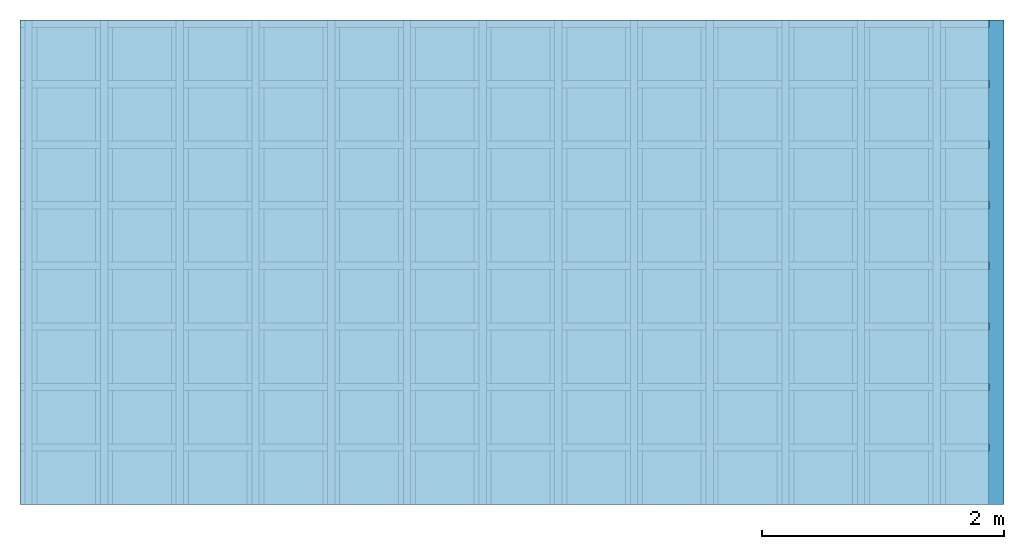
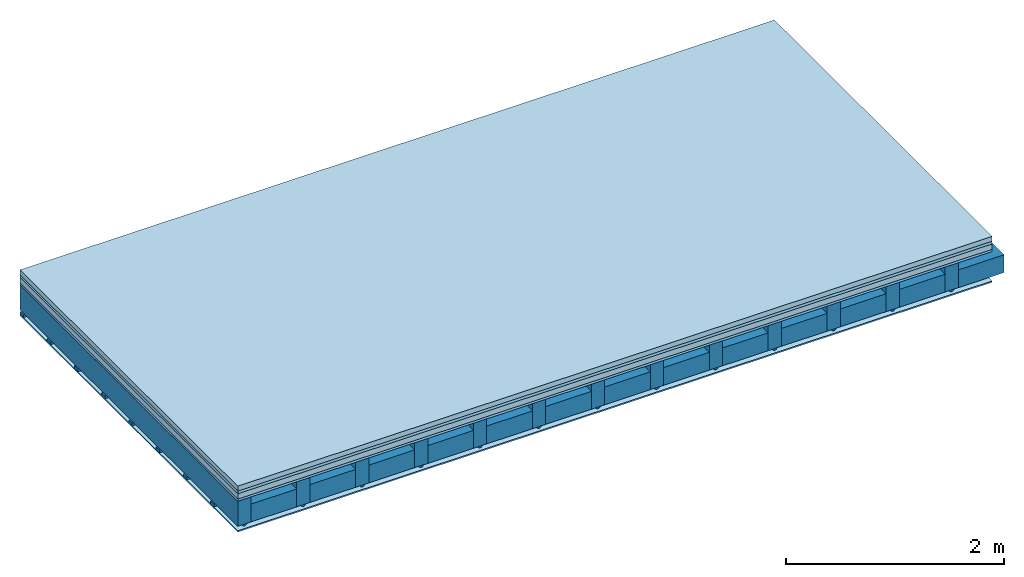
# One storey: 5 plates, 4 members, 1 element without a shape of its own.
"""IFC4 building model written with IfcOpenShell, lengths in metres."""

from ifc_helpers import new_model, si_unit, derived_unit, direction, frame, frame_2d, origin, origin_with_axes, place, context, project, spatial, polyline, rectangle, outline, extrude, material, layer, layer_set, type_object, element, aggregate, save


model = new_model("IFC4")

# Units and contexts
plan_context = context("Plan", 3, precision=1e-05, world=origin(), true_north=direction((0.0, 1.0)))
model_context = context("Model", 3, precision=1e-05, world=origin(), true_north=direction((0.0, 1.0)))
ifc_project = project(units=[si_unit("LENGTHUNIT", "METRE"), derived_unit("SOUNDPRESSUREUNIT", [(si_unit("PRESSUREUNIT", "PASCAL", prefix="MICRO"), 0)]), si_unit("ENERGYUNIT", "JOULE", prefix="MEGA"), si_unit("MASSUNIT", "GRAM", prefix="KILO"), derived_unit("THERMALTRANSMITTANCEUNIT", [(si_unit("POWERUNIT", "WATT"), 1), (si_unit("AREAUNIT", "SQUARE_METRE"), -1), (si_unit("THERMODYNAMICTEMPERATUREUNIT", "KELVIN"), -1)]), derived_unit("AREADENSITYUNIT", [(si_unit("MASSUNIT", "GRAM", prefix="KILO"), 1), (si_unit("AREAUNIT", "SQUARE_METRE"), -1)]), derived_unit("USERDEFINED", [(si_unit("ENERGYUNIT", "JOULE", prefix="MEGA"), 1), (si_unit("AREAUNIT", "SQUARE_METRE"), -1)])], contexts=[plan_context, model_context])

# Site, building, storey
site = spatial("IfcSite", under=ifc_project)
building_placement = place(None, origin())
building = spatial("IfcBuilding", under=site, at=building_placement)
storey_placement = place(building_placement, origin())
storey = spatial("IfcBuildingStorey", under=building, at=storey_placement)

# Slab, members, plates
ifc_material_1 = material(Category="04.005")
ifc_layer_1 = layer(ifc_material_1, 0.055, Name="On-material")
ifc_material_2 = material()
ifc_layer_2 = layer(ifc_material_2, 0.03, Name="Impact sound insulation")
ifc_material_3 = material(Name="Cement panels, glued on sub-floor", Category="02.007")
ifc_layer_3 = layer(ifc_material_3, 0.06, Name="on Supporting structure")
ifc_material_4 = material(Category="07.001")
ifc_layer_4 = layer(ifc_material_4, 0.025, Name="Sub-floor")
ifc_material_5 = material(Name="of the art")
ifc_layer_5 = layer(ifc_material_5, 0.0, Name="Bond")
ifc_layer_6 = layer(None, 0.28, Name="Supporting structure")
ifc_material_6 = material(Name="no composite action")
ifc_layer_7 = layer(ifc_material_6, 0.0, Name="Bond")
ifc_layer_8 = layer(None, 0.02, Name="Coupling")
ifc_layer_9 = layer(None, 0.03, Name="Battens / profiles")
ifc_material_7 = material(Category="03.007")
ifc_layer_10 = layer(ifc_material_7, 0.015, Name="Ceiling covering 1st layer")
ifc_material_8 = material(Name="Glued joints")
ifc_layer_11 = layer(ifc_material_8, 0.0, Name="Surface / treatment")
ifc_layer_set = layer_set([ifc_layer_1, ifc_layer_2, ifc_layer_3, ifc_layer_4, ifc_layer_5, ifc_layer_6, ifc_layer_7, ifc_layer_8, ifc_layer_9, ifc_layer_10, ifc_layer_11])
slab_type = type_object("IfcSlabType", Name="A0255", PredefinedType="NOTDEFINED", material=ifc_layer_set)
slab_placement = place(None, frame((0.0, 0.0, 0.0), z_axis=(0.0, 0.0, -1.0), x_axis=(1.0, 0.0, 0.0)))
slab = element("IfcSlab", 1, at=slab_placement, inside=storey, type_object=slab_type, material=ifc_layer_set, Name="Slab #1")
ifc_material_9 = material()
member_1_placement = place(slab_placement, origin())
member_1 = element("IfcMember", 2, at=member_1_placement, material=ifc_material_9, Name="Supporting structure", context=plan_context, shape_type="SweptSolid", body=[
    extrude(rectangle(XDim=0.14, YDim=0.28, at=frame_2d((0.07, 0.14), x_axis=(1.0, 0.0))), frame((0.0, 4.0, 0.17), z_axis=(0.0, -1.0, 0.0), x_axis=(1.0, 0.0, 0.0)), (0.0, 0.0, 1.0), 4.0),
    extrude(rectangle(XDim=0.14, YDim=0.28, at=frame_2d((0.07, 0.14), x_axis=(1.0, 0.0))), frame((0.625, 4.0, 0.17), z_axis=(0.0, -1.0, 0.0), x_axis=(1.0, 0.0, 0.0)), (0.0, 0.0, 1.0), 4.0),
    extrude(rectangle(XDim=0.14, YDim=0.28, at=frame_2d((0.07, 0.14), x_axis=(1.0, 0.0))), frame((1.25, 4.0, 0.17), z_axis=(0.0, -1.0, 0.0), x_axis=(1.0, 0.0, 0.0)), (0.0, 0.0, 1.0), 4.0),
    extrude(rectangle(XDim=0.14, YDim=0.28, at=frame_2d((0.07, 0.14), x_axis=(1.0, 0.0))), frame((1.875, 4.0, 0.17), z_axis=(0.0, -1.0, 0.0), x_axis=(1.0, 0.0, 0.0)), (0.0, 0.0, 1.0), 4.0),
    extrude(rectangle(XDim=0.14, YDim=0.28, at=frame_2d((0.07, 0.14), x_axis=(1.0, 0.0))), frame((2.5, 4.0, 0.17), z_axis=(0.0, -1.0, 0.0), x_axis=(1.0, 0.0, 0.0)), (0.0, 0.0, 1.0), 4.0),
    extrude(rectangle(XDim=0.14, YDim=0.28, at=frame_2d((0.07, 0.14), x_axis=(1.0, 0.0))), frame((3.125, 4.0, 0.17), z_axis=(0.0, -1.0, 0.0), x_axis=(1.0, 0.0, 0.0)), (0.0, 0.0, 1.0), 4.0),
    extrude(rectangle(XDim=0.14, YDim=0.28, at=frame_2d((0.07, 0.14), x_axis=(1.0, 0.0))), frame((3.75, 4.0, 0.17), z_axis=(0.0, -1.0, 0.0), x_axis=(1.0, 0.0, 0.0)), (0.0, 0.0, 1.0), 4.0),
    extrude(rectangle(XDim=0.14, YDim=0.28, at=frame_2d((0.07, 0.14), x_axis=(1.0, 0.0))), frame((4.375, 4.0, 0.17), z_axis=(0.0, -1.0, 0.0), x_axis=(1.0, 0.0, 0.0)), (0.0, 0.0, 1.0), 4.0),
    extrude(rectangle(XDim=0.14, YDim=0.28, at=frame_2d((0.07, 0.14), x_axis=(1.0, 0.0))), frame((5.0, 4.0, 0.17), z_axis=(0.0, -1.0, 0.0), x_axis=(1.0, 0.0, 0.0)), (0.0, 0.0, 1.0), 4.0),
    extrude(rectangle(XDim=0.14, YDim=0.28, at=frame_2d((0.07, 0.14), x_axis=(1.0, 0.0))), frame((5.625, 4.0, 0.17), z_axis=(0.0, -1.0, 0.0), x_axis=(1.0, 0.0, 0.0)), (0.0, 0.0, 1.0), 4.0),
    extrude(rectangle(XDim=0.14, YDim=0.28, at=frame_2d((0.07, 0.14), x_axis=(1.0, 0.0))), frame((6.25, 4.0, 0.17), z_axis=(0.0, -1.0, 0.0), x_axis=(1.0, 0.0, 0.0)), (0.0, 0.0, 1.0), 4.0),
    extrude(rectangle(XDim=0.14, YDim=0.28, at=frame_2d((0.07, 0.14), x_axis=(1.0, 0.0))), frame((6.875, 4.0, 0.17), z_axis=(0.0, -1.0, 0.0), x_axis=(1.0, 0.0, 0.0)), (0.0, 0.0, 1.0), 4.0),
    extrude(rectangle(XDim=0.14, YDim=0.28, at=frame_2d((0.07, 0.14), x_axis=(1.0, 0.0))), frame((7.5, 4.0, 0.17), z_axis=(0.0, -1.0, 0.0), x_axis=(1.0, 0.0, 0.0)), (0.0, 0.0, 1.0), 4.0),
])
ifc_material_10 = material()
member_2_placement = place(slab_placement, origin())
member_2 = element("IfcMember", 3, at=member_2_placement, material=ifc_material_10, Name="Cavity", context=plan_context, shape_type="SweptSolid", body=[
    extrude(rectangle(XDim=0.485, YDim=0.2, at=frame_2d((0.2425, 0.1), x_axis=(1.0, 0.0))), frame((0.14, 4.0, 0.25), z_axis=(0.0, -1.0, 0.0), x_axis=(1.0, 0.0, 0.0)), (0.0, 0.0, 1.0), 4.0),
    extrude(rectangle(XDim=0.485, YDim=0.2, at=frame_2d((0.2425, 0.1), x_axis=(1.0, 0.0))), frame((0.765, 4.0, 0.25), z_axis=(0.0, -1.0, 0.0), x_axis=(1.0, 0.0, 0.0)), (0.0, 0.0, 1.0), 4.0),
    extrude(rectangle(XDim=0.485, YDim=0.2, at=frame_2d((0.2425, 0.1), x_axis=(1.0, 0.0))), frame((1.39, 4.0, 0.25), z_axis=(0.0, -1.0, 0.0), x_axis=(1.0, 0.0, 0.0)), (0.0, 0.0, 1.0), 4.0),
    extrude(rectangle(XDim=0.485, YDim=0.2, at=frame_2d((0.2425, 0.1), x_axis=(1.0, 0.0))), frame((2.015, 4.0, 0.25), z_axis=(0.0, -1.0, 0.0), x_axis=(1.0, 0.0, 0.0)), (0.0, 0.0, 1.0), 4.0),
    extrude(rectangle(XDim=0.485, YDim=0.2, at=frame_2d((0.2425, 0.1), x_axis=(1.0, 0.0))), frame((2.64, 4.0, 0.25), z_axis=(0.0, -1.0, 0.0), x_axis=(1.0, 0.0, 0.0)), (0.0, 0.0, 1.0), 4.0),
    extrude(rectangle(XDim=0.485, YDim=0.2, at=frame_2d((0.2425, 0.1), x_axis=(1.0, 0.0))), frame((3.265, 4.0, 0.25), z_axis=(0.0, -1.0, 0.0), x_axis=(1.0, 0.0, 0.0)), (0.0, 0.0, 1.0), 4.0),
    extrude(rectangle(XDim=0.485, YDim=0.2, at=frame_2d((0.2425, 0.1), x_axis=(1.0, 0.0))), frame((3.89, 4.0, 0.25), z_axis=(0.0, -1.0, 0.0), x_axis=(1.0, 0.0, 0.0)), (0.0, 0.0, 1.0), 4.0),
    extrude(rectangle(XDim=0.485, YDim=0.2, at=frame_2d((0.2425, 0.1), x_axis=(1.0, 0.0))), frame((4.515, 4.0, 0.25), z_axis=(0.0, -1.0, 0.0), x_axis=(1.0, 0.0, 0.0)), (0.0, 0.0, 1.0), 4.0),
    extrude(rectangle(XDim=0.485, YDim=0.2, at=frame_2d((0.2425, 0.1), x_axis=(1.0, 0.0))), frame((5.14, 4.0, 0.25), z_axis=(0.0, -1.0, 0.0), x_axis=(1.0, 0.0, 0.0)), (0.0, 0.0, 1.0), 4.0),
    extrude(rectangle(XDim=0.485, YDim=0.2, at=frame_2d((0.2425, 0.1), x_axis=(1.0, 0.0))), frame((5.765, 4.0, 0.25), z_axis=(0.0, -1.0, 0.0), x_axis=(1.0, 0.0, 0.0)), (0.0, 0.0, 1.0), 4.0),
    extrude(rectangle(XDim=0.485, YDim=0.2, at=frame_2d((0.2425, 0.1), x_axis=(1.0, 0.0))), frame((6.39, 4.0, 0.25), z_axis=(0.0, -1.0, 0.0), x_axis=(1.0, 0.0, 0.0)), (0.0, 0.0, 1.0), 4.0),
    extrude(rectangle(XDim=0.485, YDim=0.2, at=frame_2d((0.2425, 0.1), x_axis=(1.0, 0.0))), frame((7.015, 4.0, 0.25), z_axis=(0.0, -1.0, 0.0), x_axis=(1.0, 0.0, 0.0)), (0.0, 0.0, 1.0), 4.0),
    extrude(rectangle(XDim=0.485, YDim=0.2, at=frame_2d((0.2425, 0.1), x_axis=(1.0, 0.0))), frame((7.64, 4.0, 0.25), z_axis=(0.0, -1.0, 0.0), x_axis=(1.0, 0.0, 0.0)), (0.0, 0.0, 1.0), 4.0),
])
ifc_material_11 = material()
member_3_placement = place(slab_placement, origin())
member_3 = element("IfcMember", 4, at=member_3_placement, material=ifc_material_11, Name="Coupling", context=plan_context, shape_type="SweptSolid", body=[
    extrude(outline(polyline([(0.0, 0.0), (0.06, 0.0), (0.04, 0.02), (0.02, 0.02), (0.0, 0.0)])), frame((0.04, 4.0, 0.45), z_axis=(0.0, -1.0, 0.0), x_axis=(1.0, 0.0, 0.0)), (0.0, 0.0, 1.0), 4.0),
    extrude(outline(polyline([(0.0, 0.0), (0.06, 0.0), (0.04, 0.02), (0.02, 0.02), (0.0, 0.0)])), frame((0.665, 4.0, 0.45), z_axis=(0.0, -1.0, 0.0), x_axis=(1.0, 0.0, 0.0)), (0.0, 0.0, 1.0), 4.0),
    extrude(outline(polyline([(0.0, 0.0), (0.06, 0.0), (0.04, 0.02), (0.02, 0.02), (0.0, 0.0)])), frame((1.29, 4.0, 0.45), z_axis=(0.0, -1.0, 0.0), x_axis=(1.0, 0.0, 0.0)), (0.0, 0.0, 1.0), 4.0),
    extrude(outline(polyline([(0.0, 0.0), (0.06, 0.0), (0.04, 0.02), (0.02, 0.02), (0.0, 0.0)])), frame((1.915, 4.0, 0.45), z_axis=(0.0, -1.0, 0.0), x_axis=(1.0, 0.0, 0.0)), (0.0, 0.0, 1.0), 4.0),
    extrude(outline(polyline([(0.0, 0.0), (0.06, 0.0), (0.04, 0.02), (0.02, 0.02), (0.0, 0.0)])), frame((2.54, 4.0, 0.45), z_axis=(0.0, -1.0, 0.0), x_axis=(1.0, 0.0, 0.0)), (0.0, 0.0, 1.0), 4.0),
    extrude(outline(polyline([(0.0, 0.0), (0.06, 0.0), (0.04, 0.02), (0.02, 0.02), (0.0, 0.0)])), frame((3.165, 4.0, 0.45), z_axis=(0.0, -1.0, 0.0), x_axis=(1.0, 0.0, 0.0)), (0.0, 0.0, 1.0), 4.0),
    extrude(outline(polyline([(0.0, 0.0), (0.06, 0.0), (0.04, 0.02), (0.02, 0.02), (0.0, 0.0)])), frame((3.79, 4.0, 0.45), z_axis=(0.0, -1.0, 0.0), x_axis=(1.0, 0.0, 0.0)), (0.0, 0.0, 1.0), 4.0),
    extrude(outline(polyline([(0.0, 0.0), (0.06, 0.0), (0.04, 0.02), (0.02, 0.02), (0.0, 0.0)])), frame((4.415, 4.0, 0.45), z_axis=(0.0, -1.0, 0.0), x_axis=(1.0, 0.0, 0.0)), (0.0, 0.0, 1.0), 4.0),
    extrude(outline(polyline([(0.0, 0.0), (0.06, 0.0), (0.04, 0.02), (0.02, 0.02), (0.0, 0.0)])), frame((5.04, 4.0, 0.45), z_axis=(0.0, -1.0, 0.0), x_axis=(1.0, 0.0, 0.0)), (0.0, 0.0, 1.0), 4.0),
    extrude(outline(polyline([(0.0, 0.0), (0.06, 0.0), (0.04, 0.02), (0.02, 0.02), (0.0, 0.0)])), frame((5.665, 4.0, 0.45), z_axis=(0.0, -1.0, 0.0), x_axis=(1.0, 0.0, 0.0)), (0.0, 0.0, 1.0), 4.0),
    extrude(outline(polyline([(0.0, 0.0), (0.06, 0.0), (0.04, 0.02), (0.02, 0.02), (0.0, 0.0)])), frame((6.29, 4.0, 0.45), z_axis=(0.0, -1.0, 0.0), x_axis=(1.0, 0.0, 0.0)), (0.0, 0.0, 1.0), 4.0),
    extrude(outline(polyline([(0.0, 0.0), (0.06, 0.0), (0.04, 0.02), (0.02, 0.02), (0.0, 0.0)])), frame((6.915, 4.0, 0.45), z_axis=(0.0, -1.0, 0.0), x_axis=(1.0, 0.0, 0.0)), (0.0, 0.0, 1.0), 4.0),
    extrude(outline(polyline([(0.0, 0.0), (0.06, 0.0), (0.04, 0.02), (0.02, 0.02), (0.0, 0.0)])), frame((7.54, 4.0, 0.45), z_axis=(0.0, -1.0, 0.0), x_axis=(1.0, 0.0, 0.0)), (0.0, 0.0, 1.0), 4.0),
])
ifc_material_12 = material()
member_4_placement = place(slab_placement, origin())
member_4 = element("IfcMember", 5, at=member_4_placement, material=ifc_material_12, Name="Battens / profiles", context=plan_context, shape_type="SweptSolid", body=[
    extrude(rectangle(XDim=0.06, YDim=0.03, at=frame_2d((0.03, 0.015), x_axis=(1.0, 0.0))), frame((0.0, 0.0, 0.47), z_axis=(1.0, 0.0, 0.0), x_axis=(0.0, 1.0, 0.0)), (0.0, 0.0, 1.0), 8.0),
    extrude(rectangle(XDim=0.06, YDim=0.03, at=frame_2d((0.03, 0.015), x_axis=(1.0, 0.0))), frame((0.0, 0.5, 0.47), z_axis=(1.0, 0.0, 0.0), x_axis=(0.0, 1.0, 0.0)), (0.0, 0.0, 1.0), 8.0),
    extrude(rectangle(XDim=0.06, YDim=0.03, at=frame_2d((0.03, 0.015), x_axis=(1.0, 0.0))), frame((0.0, 1.0, 0.47), z_axis=(1.0, 0.0, 0.0), x_axis=(0.0, 1.0, 0.0)), (0.0, 0.0, 1.0), 8.0),
    extrude(rectangle(XDim=0.06, YDim=0.03, at=frame_2d((0.03, 0.015), x_axis=(1.0, 0.0))), frame((0.0, 1.5, 0.47), z_axis=(1.0, 0.0, 0.0), x_axis=(0.0, 1.0, 0.0)), (0.0, 0.0, 1.0), 8.0),
    extrude(rectangle(XDim=0.06, YDim=0.03, at=frame_2d((0.03, 0.015), x_axis=(1.0, 0.0))), frame((0.0, 2.0, 0.47), z_axis=(1.0, 0.0, 0.0), x_axis=(0.0, 1.0, 0.0)), (0.0, 0.0, 1.0), 8.0),
    extrude(rectangle(XDim=0.06, YDim=0.03, at=frame_2d((0.03, 0.015), x_axis=(1.0, 0.0))), frame((0.0, 2.5, 0.47), z_axis=(1.0, 0.0, 0.0), x_axis=(0.0, 1.0, 0.0)), (0.0, 0.0, 1.0), 8.0),
    extrude(rectangle(XDim=0.06, YDim=0.03, at=frame_2d((0.03, 0.015), x_axis=(1.0, 0.0))), frame((0.0, 3.0, 0.47), z_axis=(1.0, 0.0, 0.0), x_axis=(0.0, 1.0, 0.0)), (0.0, 0.0, 1.0), 8.0),
    extrude(rectangle(XDim=0.06, YDim=0.03, at=frame_2d((0.03, 0.015), x_axis=(1.0, 0.0))), frame((0.0, 3.5, 0.47), z_axis=(1.0, 0.0, 0.0), x_axis=(0.0, 1.0, 0.0)), (0.0, 0.0, 1.0), 8.0),
])
plate_1_placement = place(slab_placement, origin())
plate_1 = element("IfcPlate", 6, at=plate_1_placement, material=ifc_material_1, Name="On-material", context=plan_context, shape_type="SweptSolid", body=[
    extrude(rectangle(XDim=8.0, YDim=4.0, at=frame_2d((4.0, 2.0), x_axis=(1.0, 0.0))), origin_with_axes(), (0.0, 0.0, 1.0), 0.055),
])
plate_2_placement = place(slab_placement, origin())
plate_2 = element("IfcPlate", 7, at=plate_2_placement, material=ifc_material_2, Name="Impact sound insulation", context=plan_context, shape_type="SweptSolid", body=[
    extrude(rectangle(XDim=8.0, YDim=4.0, at=frame_2d((4.0, 2.0), x_axis=(1.0, 0.0))), frame((0.0, 0.0, 0.055), z_axis=(0.0, 0.0, 1.0), x_axis=(1.0, 0.0, 0.0)), (0.0, 0.0, 1.0), 0.03),
])
plate_3_placement = place(slab_placement, origin())
plate_3 = element("IfcPlate", 8, at=plate_3_placement, material=ifc_material_3, Name="on Supporting structure", context=plan_context, shape_type="SweptSolid", body=[
    extrude(rectangle(XDim=8.0, YDim=4.0, at=frame_2d((4.0, 2.0), x_axis=(1.0, 0.0))), frame((0.0, 0.0, 0.085), z_axis=(0.0, 0.0, 1.0), x_axis=(1.0, 0.0, 0.0)), (0.0, 0.0, 1.0), 0.06),
])
plate_4_placement = place(slab_placement, origin())
plate_4 = element("IfcPlate", 9, at=plate_4_placement, material=ifc_material_4, Name="Sub-floor", context=plan_context, shape_type="SweptSolid", body=[
    extrude(rectangle(XDim=8.0, YDim=4.0, at=frame_2d((4.0, 2.0), x_axis=(1.0, 0.0))), frame((0.0, 0.0, 0.145), z_axis=(0.0, 0.0, 1.0), x_axis=(1.0, 0.0, 0.0)), (0.0, 0.0, 1.0), 0.025),
])
plate_5_placement = place(slab_placement, origin())
plate_5 = element("IfcPlate", 10, at=plate_5_placement, material=ifc_material_7, Name="Ceiling covering 1st layer", context=plan_context, shape_type="SweptSolid", body=[
    extrude(rectangle(XDim=8.0, YDim=4.0, at=frame_2d((4.0, 2.0), x_axis=(1.0, 0.0))), frame((0.0, 0.0, 0.5), z_axis=(0.0, 0.0, 1.0), x_axis=(1.0, 0.0, 0.0)), (0.0, 0.0, 1.0), 0.015),
])
aggregate(slab, [plate_1, plate_2, plate_3, plate_4, member_1, member_2, member_3, member_4, plate_5])

save(model, "model.ifc")
